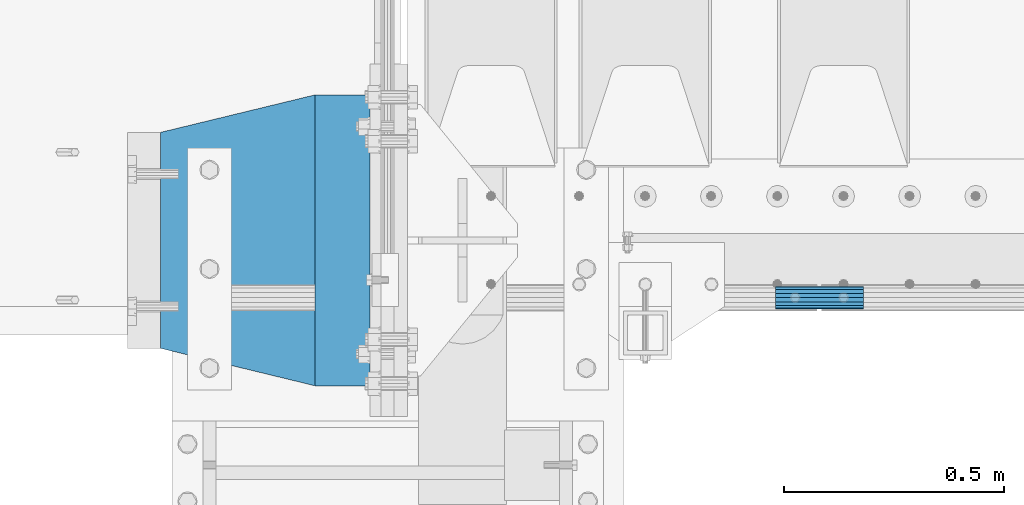
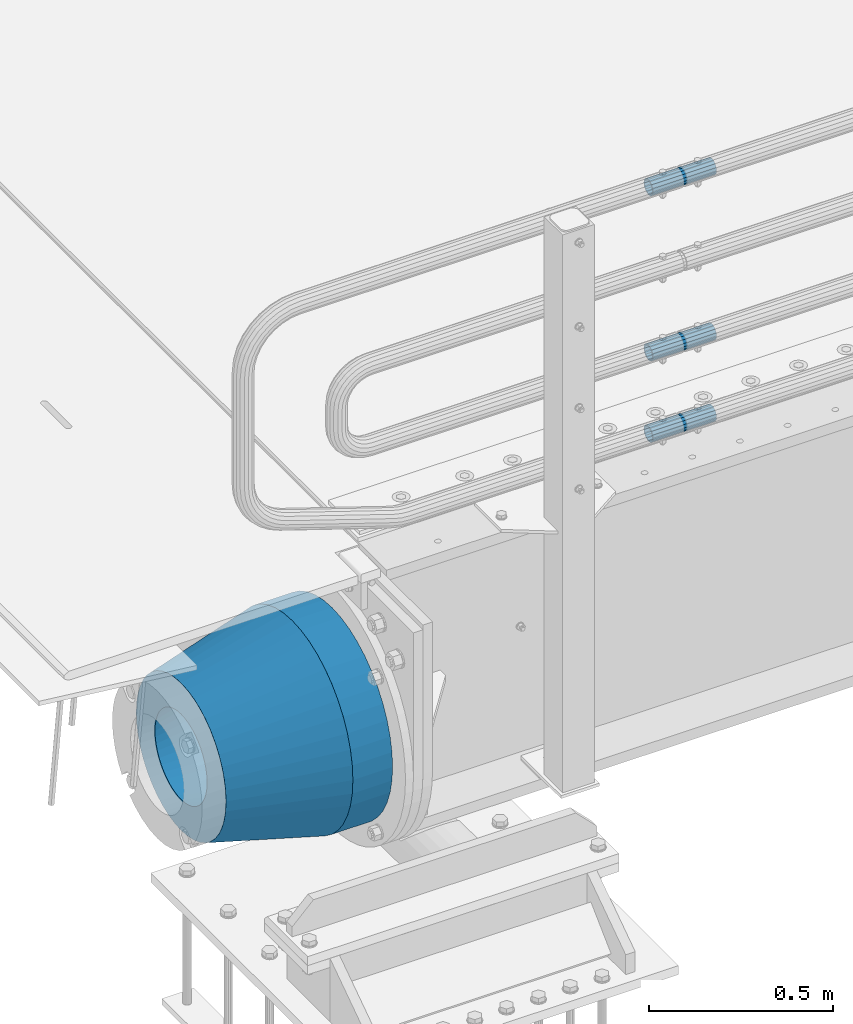
# One storey, part 138 of 242: 5 beams.
"""IFC2X3 building model written with IfcOpenShell, lengths in millimetres."""

from ifc_helpers import new_model, si_unit, frame, origin_with_axes, place, context, subcontext, project, spatial, faceted_brep, material, type_object, element, save


model = new_model("IFC2X3")

# Units and contexts
model_context = context("Model", 3, precision=1e-05, world=origin_with_axes())
body_context = subcontext(model_context, "Body", "Model", "MODEL_VIEW")
ifc_project = project(units=[si_unit("LENGTHUNIT", "METRE", prefix="MILLI"), si_unit("AREAUNIT", "SQUARE_METRE"), si_unit("VOLUMEUNIT", "CUBIC_METRE"), si_unit("MASSUNIT", "GRAM", prefix="KILO"), si_unit("TIMEUNIT", "SECOND"), si_unit("PLANEANGLEUNIT", "RADIAN"), si_unit("SOLIDANGLEUNIT", "STERADIAN"), si_unit("THERMODYNAMICTEMPERATUREUNIT", "DEGREE_CELSIUS"), si_unit("LUMINOUSINTENSITYUNIT", "LUMEN")], contexts=[model_context])

# Site, building, storey
site_placement = place(None, origin_with_axes())
site = spatial("IfcSite", under=ifc_project, at=site_placement, CompositionType="ELEMENT")
building_placement = place(site_placement, origin_with_axes())
building = spatial("IfcBuilding", under=site, at=building_placement, Name="Standard", CompositionType="ELEMENT")
storey_placement = place(building_placement, origin_with_axes())
storey = spatial("IfcBuildingStorey", under=building, at=storey_placement, Name="Undefined", CompositionType="ELEMENT", Elevation=0.0)

# Beams
ifc_material_1 = material()
beam_type_1 = type_object("IfcBeamType", PredefinedType="NOTDEFINED")
beam_1_placement = place(storey_placement, frame((-41605.0024970001, -24129.8499999996, 149.849999999726), z_axis=(0.0, 0.0, 1.0), x_axis=(1.0, 0.0, 0.0)))
element("IfcBeam", 1, at=beam_1_placement, inside=storey, type_object=beam_type_1, material=ifc_material_1, context=body_context, shape_type="Brep", body=[
    faceted_brep([(0.0, -21.9000000000015, 0.0), (0.0, -20.232961761998, 8.38076716879547), (200.0, -20.232961761998, 8.38076716879547), (200.0, -21.9000000000015, 0.0), (0.0, -15.4856385079838, 15.4856385079854), (200.0, -15.4856385079838, 15.4856385079854), (0.0, -8.38076716879368, 20.2329617619972), (200.0, -8.38076716879368, 20.2329617619972), (0.0, 0.0, 21.9), (200.0, 0.0, 21.9), (0.0, 8.38076716879368, 20.2329617619972), (200.0, 8.38076716879368, 20.2329617619972), (0.0, 15.4856385079838, 15.4856385079854), (200.0, 15.4856385079838, 15.4856385079854), (0.0, 20.232961761998, 8.38076716879547), (200.0, 20.232961761998, 8.38076716879547), (0.0, 21.9000000000015, 0.0), (200.0, 21.9000000000015, 0.0), (0.0, 20.232961761998, -8.38076716879547), (200.0, 20.232961761998, -8.38076716879547), (0.0, 15.4856385079838, -15.4856385079854), (200.0, 15.4856385079838, -15.4856385079854), (0.0, 8.38076716879368, -20.2329617619972), (200.0, 8.38076716879368, -20.2329617619972), (0.0, 0.0, -21.9), (200.0, 0.0, -21.9), (0.0, -8.38076716879368, -20.2329617619972), (200.0, -8.38076716879368, -20.2329617619972), (0.0, -15.4856385079838, -15.4856385079854), (200.0, -15.4856385079838, -15.4856385079854), (0.0, -20.232961761998, -8.38076716879547), (200.0, -20.232961761998, -8.38076716879547), (0.0, -25.5, 0.0), (0.0, -23.5589280790373, -9.7584275253098), (200.0, -23.5589280790373, -9.7584275253098), (200.0, -25.5, 0.0), (0.0, -18.0312229202573, -18.031222920257), (200.0, -18.0312229202573, -18.031222920257), (0.0, -9.75842752531025, -23.5589280790378), (200.0, -9.75842752531025, -23.5589280790378), (0.0, 0.0, -25.5), (200.0, 0.0, -25.5), (0.0, 9.75842752531025, -23.5589280790378), (200.0, 9.75842752531025, -23.5589280790378), (0.0, 18.0312229202573, -18.031222920257), (200.0, 18.0312229202573, -18.031222920257), (0.0, 23.5589280790373, -9.7584275253098), (200.0, 23.5589280790373, -9.7584275253098), (0.0, 25.5, 0.0), (200.0, 25.5, 0.0), (0.0, 23.5589280790373, 9.7584275253098), (200.0, 23.5589280790373, 9.7584275253098), (0.0, 18.0312229202573, 18.031222920257), (200.0, 18.0312229202573, 18.031222920257), (0.0, 9.75842752531025, 23.5589280790378), (200.0, 9.75842752531025, 23.5589280790378), (0.0, 0.0, 25.5), (200.0, 0.0, 25.5), (0.0, -9.75842752531025, 23.5589280790378), (200.0, -9.75842752531025, 23.5589280790378), (0.0, -18.0312229202573, 18.031222920257), (200.0, -18.0312229202573, 18.031222920257), (0.0, -23.5589280790373, 9.7584275253098), (200.0, -23.5589280790373, 9.7584275253098)], [[[0, 1, 2, 3]], [[1, 4, 5, 2]], [[4, 6, 7, 5]], [[6, 8, 9, 7]], [[8, 10, 11, 9]], [[10, 12, 13, 11]], [[12, 14, 15, 13]], [[14, 16, 17, 15]], [[16, 18, 19, 17]], [[18, 20, 21, 19]], [[20, 22, 23, 21]], [[22, 24, 25, 23]], [[24, 26, 27, 25]], [[26, 28, 29, 27]], [[28, 30, 31, 29]], [[30, 0, 3, 31]], [[32, 33, 34, 35]], [[33, 36, 37, 34]], [[36, 38, 39, 37]], [[38, 40, 41, 39]], [[40, 42, 43, 41]], [[42, 44, 45, 43]], [[44, 46, 47, 45]], [[46, 48, 49, 47]], [[48, 50, 51, 49]], [[50, 52, 53, 51]], [[52, 54, 55, 53]], [[54, 56, 57, 55]], [[56, 58, 59, 57]], [[58, 60, 61, 59]], [[60, 62, 63, 61]], [[62, 32, 35, 63]], [[37, 39, 41, 43, 45, 47, 49, 51, 53, 55, 57, 59, 61, 63, 35, 34], [5, 7, 9, 11, 13, 15, 17, 19, 21, 23, 25, 27, 29, 31, 3, 2]], [[62, 60, 58, 56, 54, 52, 50, 48, 46, 44, 42, 40, 38, 36, 33, 32], [30, 28, 26, 24, 22, 20, 18, 16, 14, 12, 10, 8, 6, 4, 1, 0]]]),
])
beam_2_placement = place(storey_placement, frame((-41605.0024970001, -24129.8499999996, 420.149999999725), z_axis=(0.0, 0.0, 1.0), x_axis=(1.0, 0.0, 0.0)))
element("IfcBeam", 2, at=beam_2_placement, inside=storey, type_object=beam_type_1, material=ifc_material_1, context=body_context, shape_type="Brep", body=[
    faceted_brep([(0.0, -21.9000000000015, 0.0), (0.0, -20.232961761998, 8.38076716879547), (200.0, -20.232961761998, 8.38076716879547), (200.0, -21.9000000000015, 0.0), (0.0, -15.4856385079838, 15.4856385079854), (200.0, -15.4856385079838, 15.4856385079854), (0.0, -8.38076716879368, 20.2329617619972), (200.0, -8.38076716879368, 20.2329617619972), (0.0, 0.0, 21.9), (200.0, 0.0, 21.9), (0.0, 8.38076716879368, 20.2329617619972), (200.0, 8.38076716879368, 20.2329617619972), (0.0, 15.4856385079838, 15.4856385079854), (200.0, 15.4856385079838, 15.4856385079854), (0.0, 20.232961761998, 8.38076716879547), (200.0, 20.232961761998, 8.38076716879547), (0.0, 21.9000000000015, 0.0), (200.0, 21.9000000000015, 0.0), (0.0, 20.232961761998, -8.38076716879547), (200.0, 20.232961761998, -8.38076716879547), (0.0, 15.4856385079838, -15.4856385079854), (200.0, 15.4856385079838, -15.4856385079854), (0.0, 8.38076716879368, -20.2329617619972), (200.0, 8.38076716879368, -20.2329617619972), (0.0, 0.0, -21.9), (200.0, 0.0, -21.9), (0.0, -8.38076716879368, -20.2329617619972), (200.0, -8.38076716879368, -20.2329617619972), (0.0, -15.4856385079838, -15.4856385079854), (200.0, -15.4856385079838, -15.4856385079854), (0.0, -20.232961761998, -8.38076716879547), (200.0, -20.232961761998, -8.38076716879547), (0.0, -25.5, 0.0), (0.0, -23.5589280790373, -9.7584275253098), (200.0, -23.5589280790373, -9.7584275253098), (200.0, -25.5, 0.0), (0.0, -18.0312229202573, -18.031222920257), (200.0, -18.0312229202573, -18.031222920257), (0.0, -9.75842752531025, -23.5589280790378), (200.0, -9.75842752531025, -23.5589280790378), (0.0, 0.0, -25.5), (200.0, 0.0, -25.5), (0.0, 9.75842752531025, -23.5589280790378), (200.0, 9.75842752531025, -23.5589280790378), (0.0, 18.0312229202573, -18.031222920257), (200.0, 18.0312229202573, -18.031222920257), (0.0, 23.5589280790373, -9.7584275253098), (200.0, 23.5589280790373, -9.7584275253098), (0.0, 25.5, 0.0), (200.0, 25.5, 0.0), (0.0, 23.5589280790373, 9.7584275253098), (200.0, 23.5589280790373, 9.7584275253098), (0.0, 18.0312229202573, 18.031222920257), (200.0, 18.0312229202573, 18.031222920257), (0.0, 9.75842752531025, 23.5589280790378), (200.0, 9.75842752531025, 23.5589280790378), (0.0, 0.0, 25.5), (200.0, 0.0, 25.5), (0.0, -9.75842752531025, 23.5589280790378), (200.0, -9.75842752531025, 23.5589280790378), (0.0, -18.0312229202573, 18.031222920257), (200.0, -18.0312229202573, 18.031222920257), (0.0, -23.5589280790373, 9.7584275253098), (200.0, -23.5589280790373, 9.7584275253098)], [[[0, 1, 2, 3]], [[1, 4, 5, 2]], [[4, 6, 7, 5]], [[6, 8, 9, 7]], [[8, 10, 11, 9]], [[10, 12, 13, 11]], [[12, 14, 15, 13]], [[14, 16, 17, 15]], [[16, 18, 19, 17]], [[18, 20, 21, 19]], [[20, 22, 23, 21]], [[22, 24, 25, 23]], [[24, 26, 27, 25]], [[26, 28, 29, 27]], [[28, 30, 31, 29]], [[30, 0, 3, 31]], [[32, 33, 34, 35]], [[33, 36, 37, 34]], [[36, 38, 39, 37]], [[38, 40, 41, 39]], [[40, 42, 43, 41]], [[42, 44, 45, 43]], [[44, 46, 47, 45]], [[46, 48, 49, 47]], [[48, 50, 51, 49]], [[50, 52, 53, 51]], [[52, 54, 55, 53]], [[54, 56, 57, 55]], [[56, 58, 59, 57]], [[58, 60, 61, 59]], [[60, 62, 63, 61]], [[62, 32, 35, 63]], [[37, 39, 41, 43, 45, 47, 49, 51, 53, 55, 57, 59, 61, 63, 35, 34], [5, 7, 9, 11, 13, 15, 17, 19, 21, 23, 25, 27, 29, 31, 3, 2]], [[62, 60, 58, 56, 54, 52, 50, 48, 46, 44, 42, 40, 38, 36, 33, 32], [30, 28, 26, 24, 22, 20, 18, 16, 14, 12, 10, 8, 6, 4, 1, 0]]]),
])
beam_3_placement = place(storey_placement, frame((-41605.0024970001, -24129.8499999996, 969.849999999726), z_axis=(0.0, 0.0, 1.0), x_axis=(1.0, 0.0, 0.0)))
element("IfcBeam", 3, at=beam_3_placement, inside=storey, type_object=beam_type_1, material=ifc_material_1, context=body_context, shape_type="Brep", body=[
    faceted_brep([(0.0, -21.9000000000015, 0.0), (0.0, -20.232961761998, 8.38076716879547), (200.0, -20.232961761998, 8.38076716879547), (200.0, -21.9000000000015, 0.0), (0.0, -15.4856385079838, 15.4856385079854), (200.0, -15.4856385079838, 15.4856385079854), (0.0, -8.38076716879368, 20.2329617619972), (200.0, -8.38076716879368, 20.2329617619972), (0.0, 0.0, 21.9), (200.0, 0.0, 21.9), (0.0, 8.38076716879368, 20.2329617619972), (200.0, 8.38076716879368, 20.2329617619972), (0.0, 15.4856385079838, 15.4856385079854), (200.0, 15.4856385079838, 15.4856385079854), (0.0, 20.232961761998, 8.38076716879547), (200.0, 20.232961761998, 8.38076716879547), (0.0, 21.9000000000015, 0.0), (200.0, 21.9000000000015, 0.0), (0.0, 20.232961761998, -8.38076716879547), (200.0, 20.232961761998, -8.38076716879547), (0.0, 15.4856385079838, -15.4856385079854), (200.0, 15.4856385079838, -15.4856385079854), (0.0, 8.38076716879368, -20.2329617619972), (200.0, 8.38076716879368, -20.2329617619972), (0.0, 0.0, -21.9), (200.0, 0.0, -21.9), (0.0, -8.38076716879368, -20.2329617619972), (200.0, -8.38076716879368, -20.2329617619972), (0.0, -15.4856385079838, -15.4856385079854), (200.0, -15.4856385079838, -15.4856385079854), (0.0, -20.232961761998, -8.38076716879547), (200.0, -20.232961761998, -8.38076716879547), (0.0, -25.5, 0.0), (0.0, -23.5589280790373, -9.7584275253098), (200.0, -23.5589280790373, -9.7584275253098), (200.0, -25.5, 0.0), (0.0, -18.0312229202573, -18.031222920257), (200.0, -18.0312229202573, -18.031222920257), (0.0, -9.75842752531025, -23.5589280790378), (200.0, -9.75842752531025, -23.5589280790378), (0.0, 0.0, -25.5), (200.0, 0.0, -25.5), (0.0, 9.75842752531025, -23.5589280790378), (200.0, 9.75842752531025, -23.5589280790378), (0.0, 18.0312229202573, -18.031222920257), (200.0, 18.0312229202573, -18.031222920257), (0.0, 23.5589280790373, -9.7584275253098), (200.0, 23.5589280790373, -9.7584275253098), (0.0, 25.5, 0.0), (200.0, 25.5, 0.0), (0.0, 23.5589280790373, 9.7584275253098), (200.0, 23.5589280790373, 9.7584275253098), (0.0, 18.0312229202573, 18.031222920257), (200.0, 18.0312229202573, 18.031222920257), (0.0, 9.75842752531025, 23.5589280790378), (200.0, 9.75842752531025, 23.5589280790378), (0.0, 0.0, 25.5), (200.0, 0.0, 25.5), (0.0, -9.75842752531025, 23.5589280790378), (200.0, -9.75842752531025, 23.5589280790378), (0.0, -18.0312229202573, 18.031222920257), (200.0, -18.0312229202573, 18.031222920257), (0.0, -23.5589280790373, 9.7584275253098), (200.0, -23.5589280790373, 9.7584275253098)], [[[0, 1, 2, 3]], [[1, 4, 5, 2]], [[4, 6, 7, 5]], [[6, 8, 9, 7]], [[8, 10, 11, 9]], [[10, 12, 13, 11]], [[12, 14, 15, 13]], [[14, 16, 17, 15]], [[16, 18, 19, 17]], [[18, 20, 21, 19]], [[20, 22, 23, 21]], [[22, 24, 25, 23]], [[24, 26, 27, 25]], [[26, 28, 29, 27]], [[28, 30, 31, 29]], [[30, 0, 3, 31]], [[32, 33, 34, 35]], [[33, 36, 37, 34]], [[36, 38, 39, 37]], [[38, 40, 41, 39]], [[40, 42, 43, 41]], [[42, 44, 45, 43]], [[44, 46, 47, 45]], [[46, 48, 49, 47]], [[48, 50, 51, 49]], [[50, 52, 53, 51]], [[52, 54, 55, 53]], [[54, 56, 57, 55]], [[56, 58, 59, 57]], [[58, 60, 61, 59]], [[60, 62, 63, 61]], [[62, 32, 35, 63]], [[37, 39, 41, 43, 45, 47, 49, 51, 53, 55, 57, 59, 61, 63, 35, 34], [5, 7, 9, 11, 13, 15, 17, 19, 21, 23, 25, 27, 29, 31, 3, 2]], [[62, 60, 58, 56, 54, 52, 50, 48, 46, 44, 42, 40, 38, 36, 33, 32], [30, 28, 26, 24, 22, 20, 18, 16, 14, 12, 10, 8, 6, 4, 1, 0]]]),
])
ifc_material_2 = material(Name="STEEL/S355N")
beam_type_2 = type_object("IfcBeamType", PredefinedType="NOTDEFINED")
beam_4_placement = place(storey_placement, frame((-42525.0, -24000.0, -515.0), z_axis=(0.0, 0.0, 1.0), x_axis=(-1.0, 0.0, 0.0)))
element("IfcBeam", 4, at=beam_4_placement, inside=storey, type_object=beam_type_2, material=ifc_material_2, context=body_context, shape_type="Brep", body=[
    faceted_brep([(0.0, -215.0, 0.0), (0.0, -212.811610004399, 30.5976902287563), (125.0, -212.811610004399, 30.5976902287563), (125.0, -215.0, 0.0), (0.0, -206.290989327117, 60.5724997209074), (125.0, -206.290989327117, 60.5724997209074), (0.0, -195.570879001221, 89.3142277954056), (125.0, -195.570879001221, 89.3142277954056), (0.0, -180.869509558703, 116.237775752953), (125.0, -180.869509558703, 116.237775752953), (0.0, -162.486158486165, 140.795057798236), (125.0, -162.486158486165, 140.795057798236), (0.0, -140.795057798237, 162.486158486165), (125.0, -140.795057798237, 162.486158486165), (0.0, -116.237775752954, 180.869509558704), (125.0, -116.237775752954, 180.869509558704), (0.0, -89.3142277954066, 195.570879001222), (125.0, -89.3142277954066, 195.570879001222), (0.0, -60.5724997209072, 206.290989327117), (125.0, -60.5724997209072, 206.290989327117), (0.0, -30.5976902287548, 212.811610004401), (125.0, -30.5976902287548, 212.811610004401), (0.0, 0.0, 215.0), (125.0, 0.0, 215.0), (0.0, 30.5976902287548, 212.811610004401), (125.0, 30.5976902287548, 212.811610004401), (0.0, 60.5724997209072, 206.290989327117), (125.0, 60.5724997209072, 206.290989327117), (0.0, 89.3142277954066, 195.570879001221), (125.0, 89.3142277954066, 195.570879001221), (0.0, 116.237775752954, 180.869509558704), (125.0, 116.237775752954, 180.869509558704), (0.0, 140.795057798237, 162.486158486165), (125.0, 140.795057798237, 162.486158486165), (0.0, 162.486158486165, 140.795057798236), (125.0, 162.486158486165, 140.795057798236), (0.0, 180.869509558703, 116.237775752953), (125.0, 180.869509558703, 116.237775752953), (0.0, 195.570879001221, 89.3142277954056), (125.0, 195.570879001221, 89.3142277954056), (0.0, 206.290989327117, 60.5724997209073), (125.0, 206.290989327117, 60.5724997209073), (0.0, 212.811610004399, 30.5976902287563), (125.0, 212.811610004399, 30.5976902287563), (0.0, 215.0, 0.0), (125.0, 215.0, 0.0), (0.0, 212.811610004399, -30.5976902287563), (125.0, 212.811610004399, -30.5976902287563), (0.0, 206.290989327117, -60.5724997209073), (125.0, 206.290989327117, -60.5724997209073), (0.0, 195.570879001221, -89.3142277954056), (125.0, 195.570879001221, -89.3142277954056), (0.0, 180.869509558703, -116.237775752954), (125.0, 180.869509558703, -116.237775752954), (0.0, 162.486158486165, -140.795057798236), (125.0, 162.486158486165, -140.795057798236), (0.0, 140.795057798237, -162.486158486166), (125.0, 140.795057798237, -162.486158486166), (0.0, 116.237775752954, -180.869509558704), (125.0, 116.237775752954, -180.869509558704), (0.0, 89.3142277954066, -195.570879001221), (125.0, 89.3142277954066, -195.570879001221), (0.0, 60.5724997209072, -206.290989327117), (125.0, 60.5724997209072, -206.290989327117), (0.0, 30.5976902287548, -212.811610004401), (125.0, 30.5976902287548, -212.811610004401), (0.0, 0.0, -215.0), (125.0, 0.0, -215.0), (0.0, -30.5976902287548, -212.811610004401), (125.0, -30.5976902287548, -212.811610004401), (0.0, -60.5724997209072, -206.290989327117), (125.0, -60.5724997209072, -206.290989327117), (0.0, -89.3142277954066, -195.570879001221), (125.0, -89.3142277954066, -195.570879001221), (0.0, -116.237775752954, -180.869509558704), (125.0, -116.237775752954, -180.869509558704), (0.0, -140.795057798237, -162.486158486166), (125.0, -140.795057798237, -162.486158486166), (0.0, -162.486158486165, -140.795057798236), (125.0, -162.486158486165, -140.795057798236), (0.0, -180.869509558703, -116.237775752953), (125.0, -180.869509558703, -116.237775752953), (0.0, -195.570879001221, -89.3142277954056), (125.0, -195.570879001221, -89.3142277954056), (0.0, -206.290989327117, -60.5724997209073), (125.0, -206.290989327117, -60.5724997209073), (0.0, -212.811610004399, -30.5976902287563), (125.0, -212.811610004399, -30.5976902287563), (0.0, -330.0, 0.0), (0.0, -326.641075820709, -46.9638966301842), (125.0, -326.641075820709, -46.9638966301842), (125.0, -330.0, 0.0), (0.0, -316.632681292784, -92.9717437576718), (125.0, -316.632681292784, -92.9717437576718), (0.0, -300.178558466992, -137.086954290623), (125.0, -300.178558466992, -137.086954290623), (0.0, -277.613665834291, -178.411469760347), (125.0, -277.613665834291, -178.411469760347), (0.0, -249.397359536906, -216.104042201944), (125.0, -249.397359536906, -216.104042201944), (0.0, -216.104042201943, -249.397359536905), (125.0, -216.104042201943, -249.397359536905), (0.0, -178.411469760347, -277.61366583429), (125.0, -178.411469760347, -277.61366583429), (0.0, -137.086954290622, -300.178558466991), (125.0, -137.086954290622, -300.178558466991), (0.0, -92.9717437576728, -316.632681292784), (125.0, -92.9717437576728, -316.632681292784), (0.0, -46.9638966301827, -326.641075820708), (125.0, -46.9638966301827, -326.641075820708), (0.0, 0.0, -330.0), (125.0, 0.0, -330.0), (0.0, 46.9638966301827, -326.641075820708), (125.0, 46.9638966301827, -326.641075820708), (0.0, 92.9717437576728, -316.632681292784), (125.0, 92.9717437576728, -316.632681292784), (0.0, 137.086954290622, -300.178558466991), (125.0, 137.086954290622, -300.178558466991), (0.0, 178.411469760347, -277.61366583429), (125.0, 178.411469760347, -277.61366583429), (0.0, 216.104042201943, -249.397359536905), (125.0, 216.104042201943, -249.397359536905), (0.0, 249.397359536906, -216.104042201944), (125.0, 249.397359536906, -216.104042201944), (0.0, 277.613665834291, -178.411469760347), (125.0, 277.613665834291, -178.411469760347), (0.0, 300.178558466992, -137.086954290623), (125.0, 300.178558466992, -137.086954290623), (0.0, 316.632681292784, -92.9717437576717), (125.0, 316.632681292784, -92.9717437576717), (0.0, 326.641075820709, -46.9638966301841), (125.0, 326.641075820709, -46.9638966301841), (0.0, 330.0, 0.0), (125.0, 330.0, 0.0), (0.0, 326.641075820709, 46.9638966301841), (125.0, 326.641075820709, 46.9638966301841), (0.0, 316.632681292784, 92.9717437576718), (125.0, 316.632681292784, 92.9717437576718), (0.0, 300.178558466992, 137.086954290622), (125.0, 300.178558466992, 137.086954290622), (0.0, 277.613665834291, 178.411469760347), (125.0, 277.613665834291, 178.411469760347), (0.0, 249.397359536906, 216.104042201944), (125.0, 249.397359536906, 216.104042201944), (0.0, 216.104042201943, 249.397359536905), (125.0, 216.104042201943, 249.397359536905), (0.0, 178.411469760347, 277.61366583429), (125.0, 178.411469760347, 277.61366583429), (0.0, 137.086954290622, 300.178558466991), (125.0, 137.086954290622, 300.178558466991), (0.0, 92.9717437576728, 316.632681292784), (125.0, 92.9717437576728, 316.632681292784), (0.0, 46.9638966301827, 326.641075820708), (125.0, 46.9638966301827, 326.641075820708), (0.0, 0.0, 330.0), (125.0, 0.0, 330.0), (0.0, -46.9638966301827, 326.641075820708), (125.0, -46.9638966301827, 326.641075820708), (0.0, -92.9717437576728, 316.632681292784), (125.0, -92.9717437576728, 316.632681292784), (0.0, -137.086954290622, 300.178558466991), (125.0, -137.086954290622, 300.178558466991), (0.0, -178.411469760347, 277.61366583429), (125.0, -178.411469760347, 277.61366583429), (0.0, -216.104042201943, 249.397359536905), (125.0, -216.104042201943, 249.397359536905), (0.0, -249.397359536906, 216.104042201944), (125.0, -249.397359536906, 216.104042201944), (0.0, -277.613665834291, 178.411469760347), (125.0, -277.613665834291, 178.411469760347), (0.0, -300.178558466992, 137.086954290623), (125.0, -300.178558466992, 137.086954290623), (0.0, -316.632681292784, 92.9717437576718), (125.0, -316.632681292784, 92.9717437576718), (0.0, -326.641075820709, 46.9638966301841), (125.0, -326.641075820709, 46.9638966301841)], [[[0, 1, 2, 3]], [[1, 4, 5, 2]], [[4, 6, 7, 5]], [[6, 8, 9, 7]], [[8, 10, 11, 9]], [[10, 12, 13, 11]], [[12, 14, 15, 13]], [[14, 16, 17, 15]], [[16, 18, 19, 17]], [[18, 20, 21, 19]], [[20, 22, 23, 21]], [[22, 24, 25, 23]], [[24, 26, 27, 25]], [[26, 28, 29, 27]], [[28, 30, 31, 29]], [[30, 32, 33, 31]], [[32, 34, 35, 33]], [[34, 36, 37, 35]], [[36, 38, 39, 37]], [[38, 40, 41, 39]], [[40, 42, 43, 41]], [[42, 44, 45, 43]], [[44, 46, 47, 45]], [[46, 48, 49, 47]], [[48, 50, 51, 49]], [[50, 52, 53, 51]], [[52, 54, 55, 53]], [[54, 56, 57, 55]], [[56, 58, 59, 57]], [[58, 60, 61, 59]], [[60, 62, 63, 61]], [[62, 64, 65, 63]], [[64, 66, 67, 65]], [[66, 68, 69, 67]], [[68, 70, 71, 69]], [[70, 72, 73, 71]], [[72, 74, 75, 73]], [[74, 76, 77, 75]], [[76, 78, 79, 77]], [[78, 80, 81, 79]], [[80, 82, 83, 81]], [[82, 84, 85, 83]], [[84, 86, 87, 85]], [[86, 0, 3, 87]], [[88, 89, 90, 91]], [[89, 92, 93, 90]], [[92, 94, 95, 93]], [[94, 96, 97, 95]], [[96, 98, 99, 97]], [[98, 100, 101, 99]], [[100, 102, 103, 101]], [[102, 104, 105, 103]], [[104, 106, 107, 105]], [[106, 108, 109, 107]], [[108, 110, 111, 109]], [[110, 112, 113, 111]], [[112, 114, 115, 113]], [[114, 116, 117, 115]], [[116, 118, 119, 117]], [[118, 120, 121, 119]], [[120, 122, 123, 121]], [[122, 124, 125, 123]], [[124, 126, 127, 125]], [[126, 128, 129, 127]], [[128, 130, 131, 129]], [[130, 132, 133, 131]], [[132, 134, 135, 133]], [[134, 136, 137, 135]], [[136, 138, 139, 137]], [[138, 140, 141, 139]], [[140, 142, 143, 141]], [[142, 144, 145, 143]], [[144, 146, 147, 145]], [[146, 148, 149, 147]], [[148, 150, 151, 149]], [[150, 152, 153, 151]], [[152, 154, 155, 153]], [[154, 156, 157, 155]], [[156, 158, 159, 157]], [[158, 160, 161, 159]], [[160, 162, 163, 161]], [[162, 164, 165, 163]], [[164, 166, 167, 165]], [[166, 168, 169, 167]], [[168, 170, 171, 169]], [[170, 172, 173, 171]], [[172, 174, 175, 173]], [[174, 88, 91, 175]], [[93, 95, 97, 99, 101, 103, 105, 107, 109, 111, 113, 115, 117, 119, 121, 123, 125, 127, 129, 131, 133, 135, 137, 139, 141, 143, 145, 147, 149, 151, 153, 155, 157, 159, 161, 163, 165, 167, 169, 171, 173, 175, 91, 90], [5, 7, 9, 11, 13, 15, 17, 19, 21, 23, 25, 27, 29, 31, 33, 35, 37, 39, 41, 43, 45, 47, 49, 51, 53, 55, 57, 59, 61, 63, 65, 67, 69, 71, 73, 75, 77, 79, 81, 83, 85, 87, 3, 2]], [[174, 172, 170, 168, 166, 164, 162, 160, 158, 156, 154, 152, 150, 148, 146, 144, 142, 140, 138, 136, 134, 132, 130, 128, 126, 124, 122, 120, 118, 116, 114, 112, 110, 108, 106, 104, 102, 100, 98, 96, 94, 92, 89, 88], [86, 84, 82, 80, 78, 76, 74, 72, 70, 68, 66, 64, 62, 60, 58, 56, 54, 52, 50, 48, 46, 44, 42, 40, 38, 36, 34, 32, 30, 28, 26, 24, 22, 20, 18, 16, 14, 12, 10, 8, 6, 4, 1, 0]]]),
])
ifc_material_3 = material(Name="SCN-500-E2")
beam_type_3 = type_object("IfcBeamType", PredefinedType="NOTDEFINED")
beam_5_placement = place(storey_placement, frame((-42650.0, -24000.0, -515.0), z_axis=(0.0, 0.0, 1.0), x_axis=(-1.0, 0.0, 0.0)))
element("IfcBeam", 5, at=beam_5_placement, inside=storey, type_object=beam_type_3, material=ifc_material_3, context=body_context, shape_type="Brep", body=[
    faceted_brep([(0.0, -330.0, 0.0), (0.0, -326.641075820709, -46.9638966301842), (350.0, -242.506253260828, -34.8671353769549), (350.0, -245.0, 0.0), (0.0, -316.632681292784, -92.9717437576718), (350.0, -235.075778535553, -69.0244764261503), (0.0, -300.178558466992, -137.086954290623), (350.0, -222.859838861856, -101.776678185462), (0.0, -277.613665834291, -178.411469760347), (350.0, -206.10711554364, -132.457000276621), (0.0, -249.397359536906, -216.104042201944), (350.0, -185.158645716794, -160.440879816595), (0.0, -216.104042201943, -249.397359536905), (350.0, -160.440879816593, -185.158645716793), (0.0, -178.411469760347, -277.61366583429), (350.0, -132.45700027662, -206.107115543639), (0.0, -137.086954290622, -300.178558466991), (350.0, -101.776678185463, -222.859838861857), (0.0, -92.9717437576728, -316.632681292784), (350.0, -69.0244764261515, -235.075778535552), (0.0, -46.9638966301827, -326.641075820708), (350.0, -34.8671353769532, -242.506253260829), (0.0, 0.0, -330.0), (350.0, 0.0, -245.0), (0.0, 46.9638966301827, -326.641075820708), (350.0, 34.8671353769532, -242.506253260829), (0.0, 92.9717437576728, -316.632681292784), (350.0, 69.0244764261515, -235.075778535552), (0.0, 137.086954290622, -300.178558466991), (350.0, 101.776678185463, -222.859838861857), (0.0, 178.411469760347, -277.61366583429), (350.0, 132.457000276623, -206.107115543639), (0.0, 216.104042201943, -249.397359536905), (350.0, 160.440879816593, -185.158645716793), (0.0, 249.397359536906, -216.104042201944), (350.0, 185.158645716794, -160.440879816595), (0.0, 277.613665834291, -178.411469760347), (350.0, 206.10711554364, -132.457000276621), (0.0, 300.178558466992, -137.086954290623), (350.0, 222.859838861856, -101.776678185462), (0.0, 316.632681292784, -92.9717437576717), (350.0, 235.075778535553, -69.0244764261502), (0.0, 326.641075820709, -46.9638966301841), (350.0, 242.506253260828, -34.8671353769548), (0.0, 330.0, 0.0), (350.0, 245.0, 0.0), (0.0, 326.641075820709, 46.9638966301841), (350.0, 242.506253260828, 34.8671353769549), (0.0, 316.632681292784, 92.9717437576718), (350.0, 235.075778535553, 69.0244764261503), (0.0, 300.178558466992, 137.086954290622), (350.0, 222.859838861856, 101.776678185462), (0.0, 277.613665834291, 178.411469760347), (350.0, 206.10711554364, 132.457000276621), (0.0, 249.397359536906, 216.104042201944), (350.0, 185.158645716794, 160.440879816595), (0.0, 216.104042201943, 249.397359536905), (350.0, 160.440879816593, 185.158645716793), (0.0, 178.411469760347, 277.61366583429), (350.0, 132.457000276623, 206.107115543639), (0.0, 137.086954290622, 300.178558466991), (350.0, 101.776678185463, 222.859838861857), (0.0, 92.9717437576728, 316.632681292784), (350.0, 69.0244764261515, 235.075778535552), (0.0, 46.9638966301827, 326.641075820708), (350.0, 34.8671353769532, 242.506253260829), (0.0, 0.0, 330.0), (350.0, 0.0, 245.0), (0.0, -46.9638966301827, 326.641075820708), (350.0, -34.8671353769532, 242.506253260829), (0.0, -92.9717437576728, 316.632681292784), (350.0, -69.0244764261515, 235.075778535552), (0.0, -137.086954290622, 300.178558466991), (350.0, -101.776678185463, 222.859838861857), (0.0, -178.411469760347, 277.61366583429), (350.0, -132.457000276623, 206.107115543639), (0.0, -216.104042201943, 249.397359536905), (350.0, -160.440879816593, 185.158645716793), (0.0, -249.397359536906, 216.104042201944), (350.0, -185.158645716794, 160.440879816595), (0.0, -277.613665834291, 178.411469760347), (350.0, -206.10711554364, 132.457000276621), (0.0, -300.178558466992, 137.086954290623), (350.0, -222.859838861856, 101.776678185462), (0.0, -316.632681292784, 92.9717437576718), (350.0, -235.075778535553, 69.0244764261503), (0.0, -326.641075820709, 46.9638966301841), (350.0, -242.506253260828, 34.8671353769549), (0.0, -227.093265923133, 0.0), (0.0, -224.781783917482, 32.3187414128026), (350.0, -140.646961357605, 20.2219801595734), (350.0, -142.093265923133, 0.0), (0.0, -217.894393008413, 63.9795664499945), (350.0, -136.337490251182, 40.032299118473), (0.0, -206.571300613232, 94.3379520160985), (350.0, -129.252581008099, 59.0276759109381), (0.0, -191.043012240007, 122.775888927343), (350.0, -119.536461949356, 76.8214194436173), (0.0, -171.625639060127, 148.714462796454), (350.0, -107.386925240015, 93.0513004111044), (0.0, -148.714462796455, 171.625639060125), (350.0, -93.0513004111053, 107.386925240013), (0.0, -122.775888927343, 191.043012240005), (350.0, -76.8214194436187, 119.536461949355), (0.0, -94.3379520160997, 206.571300613232), (350.0, -59.0276759109365, 129.252581008098), (0.0, -63.9795664499943, 217.894393008413), (350.0, -40.032299118473, 136.337490251181), (0.0, -32.3187414128042, 224.781783917484), (350.0, -20.2219801595747, 140.646961357605), (0.0, 0.0, 227.093265923131), (350.0, 0.0, 142.093265923131), (0.0, 32.3187414128042, 224.781783917484), (350.0, 20.2219801595747, 140.646961357605), (0.0, 63.9795664499943, 217.894393008413), (350.0, 40.032299118473, 136.337490251181), (0.0, 94.3379520160997, 206.571300613232), (350.0, 59.0276759109365, 129.252581008098), (0.0, 122.775888927343, 191.043012240005), (350.0, 76.8214194436187, 119.536461949355), (0.0, 148.714462796455, 171.625639060125), (350.0, 93.0513004111053, 107.386925240013), (0.0, 171.625639060127, 148.714462796454), (350.0, 107.386925240015, 93.0513004111044), (0.0, 191.043012240007, 122.775888927343), (350.0, 119.536461949356, 76.8214194436174), (0.0, 206.571300613232, 94.3379520160985), (350.0, 129.252581008099, 59.0276759109382), (0.0, 217.894393008413, 63.9795664499945), (350.0, 136.337490251182, 40.032299118473), (0.0, 224.781783917482, 32.3187414128025), (350.0, 140.646961357605, 20.2219801595733), (0.0, 227.093265923133, 0.0), (350.0, 142.093265923133, 0.0), (0.0, 224.781783917482, -32.3187414128026), (350.0, 140.646961357605, -20.2219801595734), (0.0, 217.894393008413, -63.9795664499945), (350.0, 136.337490251182, -40.032299118473), (0.0, 206.571300613232, -94.3379520160985), (350.0, 129.252581008099, -59.0276759109381), (0.0, 191.043012240007, -122.775888927343), (350.0, 119.536461949356, -76.8214194436174), (0.0, 171.625639060127, -148.714462796454), (350.0, 107.386925240015, -93.0513004111044), (0.0, 148.714462796455, -171.625639060125), (350.0, 93.0513004111053, -107.386925240013), (0.0, 122.775888927343, -191.043012240005), (350.0, 76.8214194436187, -119.536461949355), (0.0, 94.3379520160997, -206.571300613232), (350.0, 59.0276759109365, -129.252581008098), (0.0, 63.9795664499943, -217.894393008413), (350.0, 40.032299118473, -136.337490251181), (0.0, 32.3187414128042, -224.781783917484), (350.0, 20.2219801595747, -140.646961357605), (0.0, 0.0, -227.093265923131), (350.0, 0.0, -142.093265923131), (0.0, -32.3187414128042, -224.781783917484), (350.0, -20.2219801595747, -140.646961357605), (0.0, -63.9795664499943, -217.894393008413), (350.0, -40.032299118473, -136.337490251181), (0.0, -94.3379520160997, -206.571300613232), (350.0, -59.0276759109365, -129.252581008098), (0.0, -122.775888927343, -191.043012240005), (350.0, -76.8214194436187, -119.536461949355), (0.0, -148.714462796455, -171.625639060125), (350.0, -93.0513004111053, -107.386925240013), (0.0, -171.625639060127, -148.714462796454), (350.0, -107.386925240015, -93.0513004111044), (0.0, -191.043012240007, -122.775888927343), (350.0, -119.536461949356, -76.8214194436174), (0.0, -206.571300613232, -94.3379520160985), (350.0, -129.252581008099, -59.0276759109381), (0.0, -217.894393008413, -63.9795664499945), (350.0, -136.337490251182, -40.032299118473), (0.0, -224.781783917482, -32.3187414128026), (350.0, -140.646961357605, -20.2219801595734)], [[[0, 1, 2, 3]], [[1, 4, 5, 2]], [[4, 6, 7, 5]], [[6, 8, 9, 7]], [[8, 10, 11, 9]], [[10, 12, 13, 11]], [[12, 14, 15, 13]], [[14, 16, 17, 15]], [[16, 18, 19, 17]], [[18, 20, 21, 19]], [[20, 22, 23, 21]], [[22, 24, 25, 23]], [[24, 26, 27, 25]], [[26, 28, 29, 27]], [[28, 30, 31, 29]], [[30, 32, 33, 31]], [[32, 34, 35, 33]], [[34, 36, 37, 35]], [[36, 38, 39, 37]], [[38, 40, 41, 39]], [[40, 42, 43, 41]], [[42, 44, 45, 43]], [[44, 46, 47, 45]], [[46, 48, 49, 47]], [[48, 50, 51, 49]], [[50, 52, 53, 51]], [[52, 54, 55, 53]], [[54, 56, 57, 55]], [[56, 58, 59, 57]], [[58, 60, 61, 59]], [[60, 62, 63, 61]], [[62, 64, 65, 63]], [[64, 66, 67, 65]], [[66, 68, 69, 67]], [[68, 70, 71, 69]], [[70, 72, 73, 71]], [[72, 74, 75, 73]], [[74, 76, 77, 75]], [[76, 78, 79, 77]], [[78, 80, 81, 79]], [[80, 82, 83, 81]], [[82, 84, 85, 83]], [[84, 86, 87, 85]], [[86, 0, 3, 87]], [[88, 89, 90, 91]], [[89, 92, 93, 90]], [[92, 94, 95, 93]], [[94, 96, 97, 95]], [[96, 98, 99, 97]], [[98, 100, 101, 99]], [[100, 102, 103, 101]], [[102, 104, 105, 103]], [[104, 106, 107, 105]], [[106, 108, 109, 107]], [[108, 110, 111, 109]], [[110, 112, 113, 111]], [[112, 114, 115, 113]], [[114, 116, 117, 115]], [[116, 118, 119, 117]], [[118, 120, 121, 119]], [[120, 122, 123, 121]], [[122, 124, 125, 123]], [[124, 126, 127, 125]], [[126, 128, 129, 127]], [[128, 130, 131, 129]], [[130, 132, 133, 131]], [[132, 134, 135, 133]], [[134, 136, 137, 135]], [[136, 138, 139, 137]], [[138, 140, 141, 139]], [[140, 142, 143, 141]], [[142, 144, 145, 143]], [[144, 146, 147, 145]], [[146, 148, 149, 147]], [[148, 150, 151, 149]], [[150, 152, 153, 151]], [[152, 154, 155, 153]], [[154, 156, 157, 155]], [[156, 158, 159, 157]], [[158, 160, 161, 159]], [[160, 162, 163, 161]], [[162, 164, 165, 163]], [[164, 166, 167, 165]], [[166, 168, 169, 167]], [[168, 170, 171, 169]], [[170, 172, 173, 171]], [[172, 174, 175, 173]], [[174, 88, 91, 175]], [[5, 7, 9, 11, 13, 15, 17, 19, 21, 23, 25, 27, 29, 31, 33, 35, 37, 39, 41, 43, 45, 47, 49, 51, 53, 55, 57, 59, 61, 63, 65, 67, 69, 71, 73, 75, 77, 79, 81, 83, 85, 87, 3, 2], [93, 95, 97, 99, 101, 103, 105, 107, 109, 111, 113, 115, 117, 119, 121, 123, 125, 127, 129, 131, 133, 135, 137, 139, 141, 143, 145, 147, 149, 151, 153, 155, 157, 159, 161, 163, 165, 167, 169, 171, 173, 175, 91, 90]], [[86, 84, 82, 80, 78, 76, 74, 72, 70, 68, 66, 64, 62, 60, 58, 56, 54, 52, 50, 48, 46, 44, 42, 40, 38, 36, 34, 32, 30, 28, 26, 24, 22, 20, 18, 16, 14, 12, 10, 8, 6, 4, 1, 0], [174, 172, 170, 168, 166, 164, 162, 160, 158, 156, 154, 152, 150, 148, 146, 144, 142, 140, 138, 136, 134, 132, 130, 128, 126, 124, 122, 120, 118, 116, 114, 112, 110, 108, 106, 104, 102, 100, 98, 96, 94, 92, 89, 88]]]),
])

save(model, "model.ifc")
